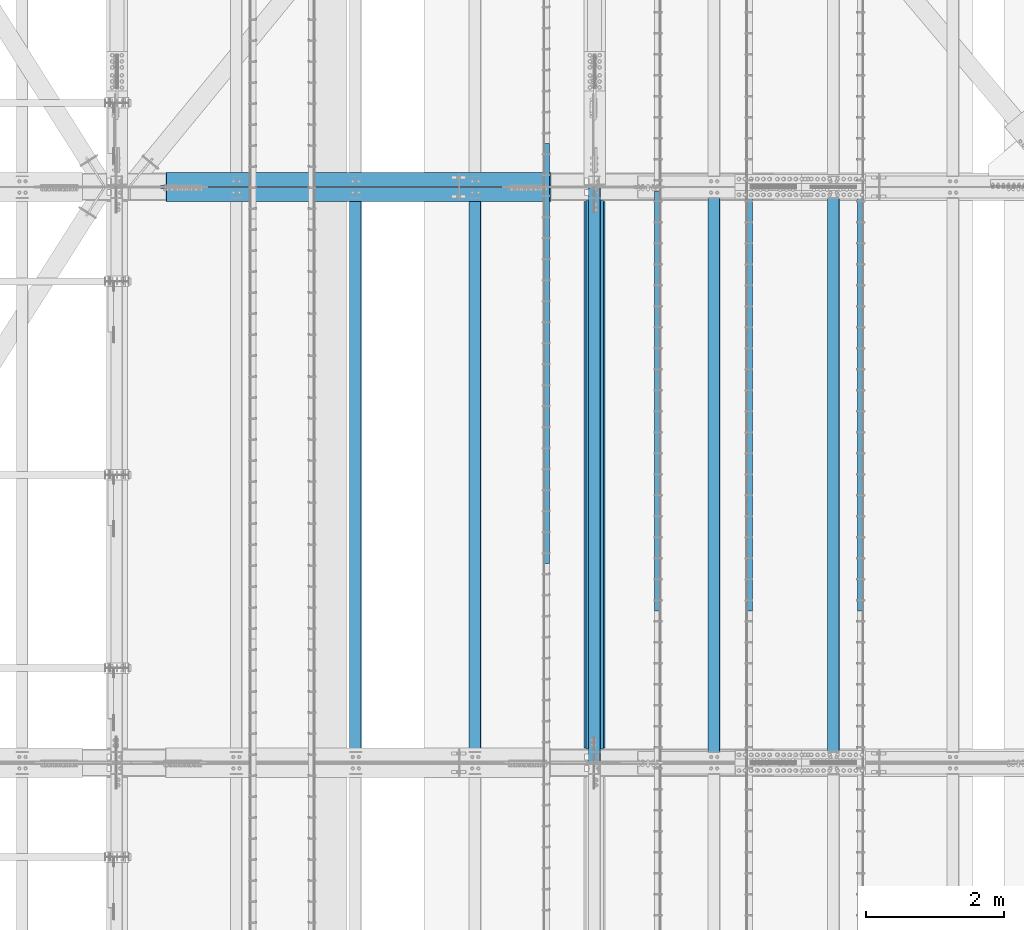
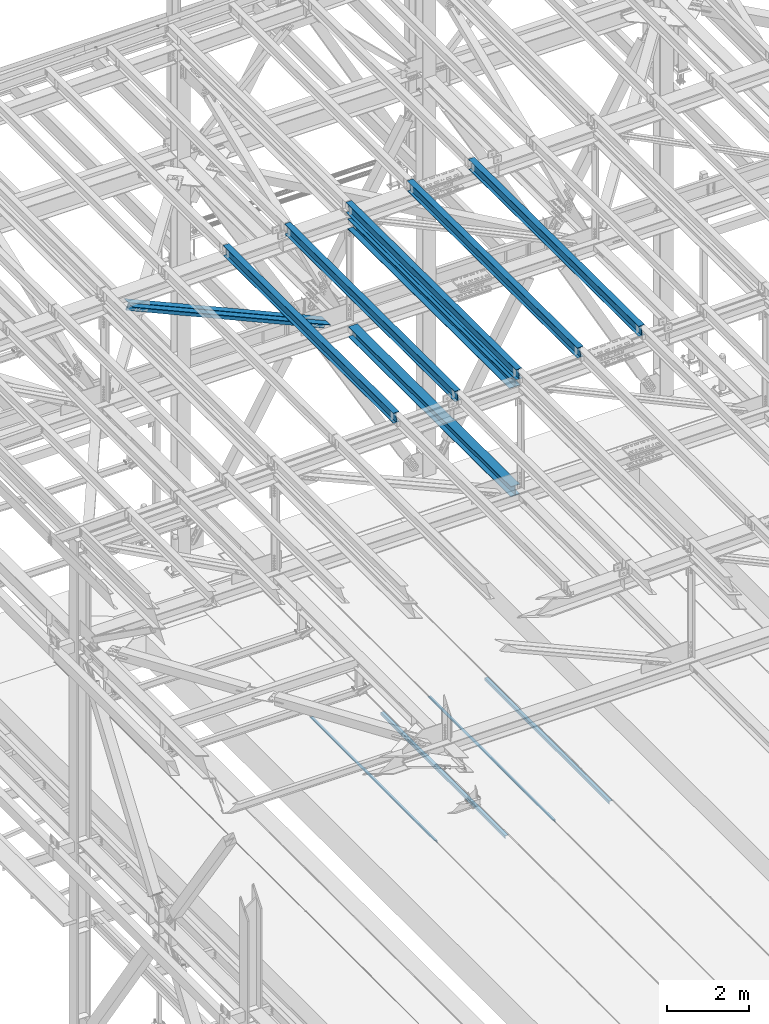
# One storey, part 1908 of 3843: 11 beams, 2 members, 13 elements without a shape of their own.
"""IFC2X3 building model written with IfcOpenShell, lengths in millimetres."""

from ifc_helpers import new_model, si_unit, frame, origin_with_axes, place, context, subcontext, project, spatial, faceted_brep, material, type_object, element, aggregate, save


model = new_model("IFC2X3")

# Units and contexts
model_context = context("Model", 3, precision=1e-05, world=origin_with_axes())
body_context = subcontext(model_context, "Body", "Model", "MODEL_VIEW")
ifc_project = project(units=[si_unit("LENGTHUNIT", "METRE", prefix="MILLI"), si_unit("AREAUNIT", "SQUARE_METRE"), si_unit("VOLUMEUNIT", "CUBIC_METRE"), si_unit("MASSUNIT", "GRAM", prefix="KILO"), si_unit("TIMEUNIT", "SECOND"), si_unit("PLANEANGLEUNIT", "RADIAN"), si_unit("SOLIDANGLEUNIT", "STERADIAN"), si_unit("THERMODYNAMICTEMPERATUREUNIT", "DEGREE_CELSIUS"), si_unit("LUMINOUSINTENSITYUNIT", "LUMEN")], contexts=[model_context])

# Site, building, storey
site_placement = place(None, origin_with_axes())
site = spatial("IfcSite", under=ifc_project, at=site_placement, CompositionType="ELEMENT")
building_placement = place(site_placement, origin_with_axes())
building = spatial("IfcBuilding", under=site, at=building_placement, Name="Undefined", CompositionType="ELEMENT")
storey_placement = place(building_placement, origin_with_axes())
storey = spatial("IfcBuildingStorey", under=building, at=storey_placement, Name="Undefined", CompositionType="ELEMENT", Elevation=0.0)

# Assembly, beam
assembly_1_placement = place(storey_placement, origin_with_axes())
assembly_1 = element("IfcElementAssembly", 1, at=assembly_1_placement, inside=storey, Name="EMBED_ANGLE", AssemblyPlace="NOTDEFINED", PredefinedType="RIGID_FRAME")
ifc_material_1 = material(Name="STEEL/A36")
beam_type_1 = type_object("IfcBeamType", Name="L3-1/2X3-1/2X5/16", PredefinedType="NOTDEFINED")
beam_1_placement = place(assembly_1_placement, frame((52851.812, 83927.822703125, 30410.15), z_axis=(0.0, 0.0, -1.0), x_axis=(0.0, -1.0, 0.0)))
beam_1 = element("IfcBeam", 2, at=beam_1_placement, type_object=beam_type_1, material=ifc_material_1, Name="EMBED_ANGLE", ObjectType="L3-1/2X3-1/2X5/16", context=body_context, shape_type="Brep", body=[
    faceted_brep([(-3.63797880709171e-12, 44.4499999999971, -44.4500000000007), (-3.63797880709171e-12, 44.4499999999971, 44.4500000000007), (6096.0, 44.4499999999971, 44.4500000000007), (6096.0, 44.4499999999971, -44.4500000000007), (-3.63797880709171e-12, 36.5124999999971, 44.4500000000007), (6096.0, 36.5124999999971, 44.4500000000007), (-3.63797880709171e-12, 36.5124999999971, -36.5125000000007), (6096.0, 36.5124999999971, -36.5125000000007), (3.63797880709171e-12, -44.4499999999971, -36.5125000000007), (6096.0, -44.4499999999971, -36.5125000000007), (3.63797880709171e-12, -44.4499999999971, -44.4500000000007), (6096.0, -44.4499999999971, -44.4500000000007)], [[[0, 1, 2, 3]], [[1, 4, 5, 2]], [[4, 6, 7, 5]], [[6, 8, 9, 7]], [[8, 10, 11, 9]], [[10, 0, 3, 11]], [[5, 7, 9, 11, 3, 2]], [[10, 8, 6, 4, 1, 0]]]),
])
aggregate(assembly_1, [beam_1])

assembly_2_placement = place(storey_placement, origin_with_axes())
assembly_2 = element("IfcElementAssembly", 3, at=assembly_2_placement, inside=storey, Name="EMBED_ANGLE", AssemblyPlace="NOTDEFINED", PredefinedType="RIGID_FRAME")
beam_2_placement = place(assembly_2_placement, frame((51238.9754423828, 77831.822703125, 30410.15), z_axis=(0.0, 0.0, -1.0), x_axis=(0.0, 1.0, 0.0)))
beam_2 = element("IfcBeam", 4, at=beam_2_placement, type_object=beam_type_1, material=ifc_material_1, Name="EMBED_ANGLE", ObjectType="L3-1/2X3-1/2X5/16", context=body_context, shape_type="Brep", body=[
    faceted_brep([(-3.63797880709171e-12, 44.4499999999971, -44.4500000000007), (-3.63797880709171e-12, 44.4499999999971, 44.4500000000007), (6096.0, 44.4499999999971, 44.4500000000007), (6096.0, 44.4499999999971, -44.4500000000007), (-3.63797880709171e-12, 36.5124999999971, 44.4500000000007), (6096.0, 36.5124999999971, 44.4500000000007), (-3.63797880709171e-12, 36.5124999999971, -36.5125000000007), (6096.0, 36.5124999999971, -36.5125000000007), (3.63797880709171e-12, -44.4499999999971, -36.5125000000007), (6096.0, -44.4499999999971, -36.5125000000007), (3.63797880709171e-12, -44.4499999999971, -44.4500000000007), (6096.0, -44.4499999999971, -44.4500000000007)], [[[0, 1, 2, 3]], [[1, 4, 5, 2]], [[4, 6, 7, 5]], [[6, 8, 9, 7]], [[8, 10, 11, 9]], [[10, 0, 3, 11]], [[5, 7, 9, 11, 3, 2]], [[10, 8, 6, 4, 1, 0]]]),
])
aggregate(assembly_2, [beam_2])

assembly_3_placement = place(storey_placement, origin_with_axes())
assembly_3 = element("IfcElementAssembly", 5, at=assembly_3_placement, inside=storey, Name="EMBED_ANGLE", AssemblyPlace="NOTDEFINED", PredefinedType="RIGID_FRAME")
beam_3_placement = place(assembly_3_placement, frame((49911.7620576172, 83927.822703125, 30410.15), z_axis=(0.0, 0.0, -1.0), x_axis=(0.0, -1.0, 0.0)))
beam_3 = element("IfcBeam", 6, at=beam_3_placement, type_object=beam_type_1, material=ifc_material_1, Name="EMBED_ANGLE", ObjectType="L3-1/2X3-1/2X5/16", context=body_context, shape_type="Brep", body=[
    faceted_brep([(-3.63797880709171e-12, 44.4499999999971, -44.4500000000007), (-3.63797880709171e-12, 44.4499999999971, 44.4500000000007), (6096.0, 44.4499999999971, 44.4500000000007), (6096.0, 44.4499999999971, -44.4500000000007), (-3.63797880709171e-12, 36.5124999999971, 44.4500000000007), (6096.0, 36.5124999999971, 44.4500000000007), (-3.63797880709171e-12, 36.5124999999971, -36.5125000000007), (6096.0, 36.5124999999971, -36.5125000000007), (3.63797880709171e-12, -44.4499999999971, -36.5125000000007), (6096.0, -44.4499999999971, -36.5125000000007), (3.63797880709171e-12, -44.4499999999971, -44.4500000000007), (6096.0, -44.4499999999971, -44.4500000000007)], [[[0, 1, 2, 3]], [[1, 4, 5, 2]], [[4, 6, 7, 5]], [[6, 8, 9, 7]], [[8, 10, 11, 9]], [[10, 0, 3, 11]], [[5, 7, 9, 11, 3, 2]], [[10, 8, 6, 4, 1, 0]]]),
])
aggregate(assembly_3, [beam_3])

assembly_4_placement = place(storey_placement, origin_with_axes())
assembly_4 = element("IfcElementAssembly", 7, at=assembly_4_placement, inside=storey, Name="EMBED_ANGLE", AssemblyPlace="NOTDEFINED", PredefinedType="RIGID_FRAME")
beam_4_placement = place(assembly_4_placement, frame((48298.8616210938, 78517.6230224609, 30410.15), z_axis=(0.0, 0.0, -1.0), x_axis=(0.0, 1.0, 0.0)))
beam_4 = element("IfcBeam", 8, at=beam_4_placement, type_object=beam_type_1, material=ifc_material_1, Name="EMBED_ANGLE", ObjectType="L3-1/2X3-1/2X5/16", context=body_context, shape_type="Brep", body=[
    faceted_brep([(-3.63797880709171e-12, 44.4499999999971, -44.4500000000007), (-3.63797880709171e-12, 44.4499999999971, 44.4500000000007), (6096.0, 44.4499999999971, 44.4500000000007), (6096.0, 44.4499999999971, -44.4500000000007), (-3.63797880709171e-12, 36.5124999999971, 44.4500000000007), (6096.0, 36.5124999999971, 44.4500000000007), (-3.63797880709171e-12, 36.5124999999971, -36.5125000000007), (6096.0, 36.5124999999971, -36.5125000000007), (3.63797880709171e-12, -44.4499999999971, -36.5125000000007), (6096.0, -44.4499999999971, -36.5125000000007), (3.63797880709171e-12, -44.4499999999971, -44.4500000000007), (6096.0, -44.4499999999971, -44.4500000000007)], [[[0, 1, 2, 3]], [[1, 4, 5, 2]], [[4, 6, 7, 5]], [[6, 8, 9, 7]], [[8, 10, 11, 9]], [[10, 0, 3, 11]], [[5, 7, 9, 11, 3, 2]], [[10, 8, 6, 4, 1, 0]]]),
])
aggregate(assembly_4, [beam_4])

assembly_5_placement = place(storey_placement, origin_with_axes())
assembly_5 = element("IfcElementAssembly", 9, at=assembly_5_placement, inside=storey, Name="BEAM", AssemblyPlace="NOTDEFINED", PredefinedType="RIGID_FRAME")
ifc_material_2 = material(Name="STEEL/A992")
beam_type_2 = type_object("IfcBeamType", Name="W12X26", PredefinedType="NOTDEFINED")
beam_5_placement = place(assembly_5_placement, frame((48993.309262336, 75629.3544032389, 45888.5907153164), z_axis=(-0.0211520981352297, 0.00549190600185831, 0.999761185340251), x_axis=(0.0, 0.999984912620133, -0.0054931349979134)))
beam_5 = element("IfcBeam", 10, at=beam_5_placement, type_object=beam_type_2, material=ifc_material_2, Name="BEAM", ObjectType="W12X26", context=body_context, shape_type="Brep", body=[
    faceted_brep([(12.7097787592938, 82.5500000013999, -155.574999999641), (12.6575034070993, 82.5500000013417, -146.049999999654), (8343.98317003538, 82.549999999188, -146.04999997573), (8344.03548122934, 82.5499999991807, -155.574999975695), (12.6482846770959, 3.17500000093423, -146.049999999646), (8343.97394720899, 3.17499999931169, -146.049999975723), (11.0440394217876, 3.17500000016298, 146.049999999559), (8342.36973726093, 3.17499999965366, 146.050000023322), (11.0532622481842, 82.5500000000247, 146.049999999566), (8342.37896008733, 82.5499999995154, 146.050000023322), (11.0009510542295, 82.5500000000393, 155.574999999531), (8342.32664889337, 82.54999999953, 155.57500002328), (10.9817675753293, -82.5499999996973, 155.574999999539), (8342.30746541447, -82.5500000001994, 155.575000023295), (11.0340787692694, -82.5499999996973, 146.049999999566), (8342.35977660841, -82.5500000002066, 146.050000023322), (11.0433015956805, -3.17499999982829, 146.049999999566), (8342.36899943482, -3.1750000003376, 146.050000023315), (12.6475471787126, -3.17499999911524, -146.049999999639), (8343.97320938286, -3.17500000067957, -146.04999997573), (12.6383284487092, -82.5499999995518, -146.049999999625), (8343.96398655647, -82.5500000005413, -146.049999975723), (12.6906038008892, -82.5499999994936, -155.574999999611), (8344.01629775044, -82.5500000005559, -155.574999975695)], [[[0, 1, 2, 3]], [[1, 4, 5, 2]], [[4, 6, 7, 5]], [[6, 8, 9, 7]], [[8, 10, 11, 9]], [[10, 12, 13, 11]], [[12, 14, 15, 13]], [[14, 16, 17, 15]], [[16, 18, 19, 17]], [[18, 20, 21, 19]], [[20, 22, 23, 21]], [[22, 0, 3, 23]], [[5, 7, 9, 11, 13, 15, 17, 19, 21, 23, 3, 2]], [[22, 20, 18, 16, 14, 12, 10, 8, 6, 4, 1, 0]]]),
])
aggregate(assembly_5, [beam_5])

assembly_6_placement = place(storey_placement, origin_with_axes())
assembly_6 = element("IfcElementAssembly", 11, at=assembly_6_placement, inside=storey, Name="BEAM", AssemblyPlace="NOTDEFINED", PredefinedType="RIGID_FRAME")
beam_6_placement = place(assembly_6_placement, frame((52460.4092623552, 75629.5061975702, 45971.7712506336), z_axis=(-0.0211520976052125, 0.00646760500322854, 0.999755349499277), x_axis=(0.0, 0.999979075464173, -0.00646905200300302)))
beam_6 = element("IfcBeam", 12, at=beam_6_placement, type_object=beam_type_2, material=ifc_material_2, Name="BEAM", ObjectType="W12X26", context=body_context, shape_type="Brep", body=[
    faceted_brep([(12.711561660195, 82.5500000001848, -155.574999999531), (12.6499564365658, 82.5500000001557, -146.049999999559), (8344.02428661397, 82.5499999998356, -146.049999984367), (8344.08589183762, 82.5499999998647, -155.574999984347), (12.6390950083442, 3.17500000028667, -146.049999999625), (8344.01342518577, 3.17499999996653, -146.049999984432), (10.7498681504803, 3.17499999969732, 146.049999999661), (8342.1241983279, 3.17499999937718, 146.050000014853), (10.7607295786875, 82.5499999995736, 146.049999999734), (8342.13505975612, 82.5499999992535, 146.050000014919), (10.6991243550729, 82.5499999995518, 155.574999999706), (8342.0734545325, 82.5499999992317, 155.575000014891), (10.676532584388, -82.5500000001921, 155.574999999582), (8342.05086276181, -82.5500000005122, 155.575000014775), (10.7381378080026, -82.550000000163, 146.049999999603), (8342.11246798544, -82.5500000004831, 146.050000014795), (10.7489992362243, -3.17500000029395, 146.049999999661), (8342.12332941365, -3.17500000061409, 146.050000014853), (12.6382260940882, -3.1749999997046, -146.049999999625), (8344.01255627151, -3.17500000002474, -146.049999984432), (12.627364665881, -82.5499999995809, -146.049999999675), (8344.00169484329, -82.549999999901, -146.049999984491), (12.6889698895102, -82.5499999995591, -155.57499999967), (8344.06330006692, -82.5499999998792, -155.57499998447)], [[[0, 1, 2, 3]], [[1, 4, 5, 2]], [[4, 6, 7, 5]], [[6, 8, 9, 7]], [[8, 10, 11, 9]], [[10, 12, 13, 11]], [[12, 14, 15, 13]], [[14, 16, 17, 15]], [[16, 18, 19, 17]], [[18, 20, 21, 19]], [[20, 22, 23, 21]], [[22, 0, 3, 23]], [[5, 7, 9, 11, 13, 15, 17, 19, 21, 23, 3, 2]], [[22, 20, 18, 16, 14, 12, 10, 8, 6, 4, 1, 0]]]),
])
aggregate(assembly_6, [beam_6])

assembly_7_placement = place(storey_placement, origin_with_axes())
assembly_7 = element("IfcElementAssembly", 13, at=assembly_7_placement, inside=storey, Name="BEAM", AssemblyPlace="NOTDEFINED", PredefinedType="RIGID_FRAME")
beam_7_placement = place(assembly_7_placement, frame((50726.8594949356, 75629.4357298818, 45930.4726800181), z_axis=(-0.0211520979501875, 0.00601465500060296, 0.999758177099607), x_axis=(-2.79999999977758e-08, 0.999981903702256, -0.00601600099820853)))
beam_7 = element("IfcBeam", 14, at=beam_7_placement, type_object=beam_type_2, material=ifc_material_2, Name="BEAM", ObjectType="W12X26", context=body_context, shape_type="Brep", body=[
    faceted_brep([(12.7107368839934, 82.5499999999956, -155.575000000114), (12.6534462637064, 82.5499999999884, -146.050000000105), (8344.0042128947, 82.5499999820022, -146.049999983406), (8344.06150351498, 82.5499999820095, -155.574999983422), (12.6433433078637, 3.1750000001266, -146.050000000017), (8343.99410993885, 3.17499998214043, -146.049999983319), (10.8864309522323, 3.17499999982101, 146.050000000068), (8342.23719758324, 3.17499998183484, 146.050000016767), (10.8965339080605, 82.5499999996755, 146.049999999974), (8342.24730053906, 82.5499999817039, 146.050000016679), (10.8392432877736, 82.5499999996755, 155.574999999983), (8342.19000991878, 82.5499999816893, 155.575000016674), (10.818229139637, -82.5500000000466, 155.575000000172), (8342.16899577064, -82.5500000180255, 155.57500001687), (10.8755197599239, -82.550000000032, 146.05000000017), (8342.22628639093, -82.5500000180109, 146.050000016869), (10.8856227157667, -3.17500000016298, 146.050000000076), (8342.23638934677, -3.17500001815642, 146.050000016774), (12.6425350713835, -3.17499999986467, -146.05000000001), (8343.9933017024, -3.17500001785083, -146.049999983319), (12.6324321155407, -82.5499999997337, -146.049999999916), (8343.98319874656, -82.5500000177126, -146.049999983217), (12.6897227358422, -82.5499999997191, -155.574999999917), (8344.04048936686, -82.5500000177053, -155.574999983219)], [[[0, 1, 2, 3]], [[1, 4, 5, 2]], [[4, 6, 7, 5]], [[6, 8, 9, 7]], [[8, 10, 11, 9]], [[10, 12, 13, 11]], [[12, 14, 15, 13]], [[14, 16, 17, 15]], [[16, 18, 19, 17]], [[18, 20, 21, 19]], [[20, 22, 23, 21]], [[22, 0, 3, 23]], [[5, 7, 9, 11, 13, 15, 17, 19, 21, 23, 3, 2]], [[22, 20, 18, 16, 14, 12, 10, 8, 6, 4, 1, 0]]]),
])
aggregate(assembly_7, [beam_7])

assembly_8_placement = place(storey_placement, origin_with_axes())
assembly_8 = element("IfcElementAssembly", 15, at=assembly_8_placement, inside=storey, Name="BEAM", AssemblyPlace="NOTDEFINED", PredefinedType="RIGID_FRAME")
beam_8_placement = place(assembly_8_placement, frame((47259.7592623296, 75629.2646229093, 45846.2545897156), z_axis=(-0.021152097592596, 0.00491481899929932, 0.999764188857371), x_axis=(0.0, 0.999987916802112, -0.00491591799902755)))
beam_8 = element("IfcBeam", 16, at=beam_8_placement, type_object=beam_type_2, material=ifc_material_2, Name="BEAM", ObjectType="W12X26", context=body_context, shape_type="Brep", body=[
    faceted_brep([(12.7087372003007, 82.5500000003158, -155.57500000023), (12.6619229916832, 82.5500000002867, -146.050000000214), (8343.962591755, 82.550000000112, -146.049999991679), (8344.00940596362, 82.5500000001339, -155.574999991695), (12.6536693221133, 3.17500000043219, -146.050000000265), (8343.95433808543, 3.17500000025757, -146.049999991723), (11.2180335913872, 3.17499999952997, 146.050000000279), (8342.51870235472, 3.17499999935535, 146.050000008821), (11.2262872609572, 82.5499999993845, 146.050000000323), (8342.52695602429, 82.5499999992026, 146.050000008865), (11.1794730523543, 82.5499999993626, 155.575000000346), (8342.48014181567, 82.549999999188, 155.575000008881), (11.1623054196389, -82.5500000003376, 155.575000000252), (8342.46297418297, -82.5500000005122, 155.575000008786), (11.2091196282563, -82.5500000003012, 146.050000000236), (8342.50978839157, -82.5500000004758, 146.05000000877), (11.2173732978263, -3.17500000045402, 146.050000000287), (8342.51804206114, -3.17500000062864, 146.050000008821), (12.6530090285523, -3.1749999995518, -146.050000000265), (8343.95367779187, -3.17499999972642, -146.04999999173), (12.6447553589969, -82.5499999994063, -146.050000000309), (8343.9454241223, -82.5499999995809, -146.049999991774), (12.6915695675852, -82.5499999993772, -155.575000000325), (8343.99223833092, -82.5499999995518, -155.57499999179)], [[[0, 1, 2, 3]], [[1, 4, 5, 2]], [[4, 6, 7, 5]], [[6, 8, 9, 7]], [[8, 10, 11, 9]], [[10, 12, 13, 11]], [[12, 14, 15, 13]], [[14, 16, 17, 15]], [[16, 18, 19, 17]], [[18, 20, 21, 19]], [[20, 22, 23, 21]], [[22, 0, 3, 23]], [[5, 7, 9, 11, 13, 15, 17, 19, 21, 23, 3, 2]], [[22, 20, 18, 16, 14, 12, 10, 8, 6, 4, 1, 0]]]),
])
aggregate(assembly_8, [beam_8])

assembly_9_placement = place(storey_placement, origin_with_axes())
assembly_9 = element("IfcElementAssembly", 17, at=assembly_9_placement, inside=storey, Name="BEAM", AssemblyPlace="NOTDEFINED", PredefinedType="RIGID_FRAME")
beam_9_placement = place(assembly_9_placement, frame((45526.2092623427, 75629.1652799087, 45803.4047149413), z_axis=(-0.0211520984919553, 0.00427626500010956, 0.999767124027909), x_axis=(0.0, 0.999990852644151, -0.00427722199847777)))
beam_9 = element("IfcBeam", 18, at=beam_9_placement, type_object=beam_type_2, material=ifc_material_2, Name="BEAM", ObjectType="W12X26", context=body_context, shape_type="Brep", body=[
    faceted_brep([(12.7075847479573, 82.549999999821, -155.575000000259), (12.6668529507879, 82.5499999998283, -146.050000000221), (8343.94306197949, 82.5499999995227, -146.049999986048), (8343.98379377666, 82.5499999995154, -155.574999986085), (12.6596716532367, 3.17499999996653, -146.050000000498), (8343.93588068195, 3.17499999966822, -146.049999986324), (11.4105632065912, 3.17500000002474, 146.050000000556), (8342.68677223532, 3.17499999971915, 146.050000014729), (11.4177445041132, 82.5499999998647, 146.050000000832), (8342.69395353284, 82.5499999995591, 146.050000015013), (11.3770127069438, 82.5499999998719, 155.575000000863), (8342.65322173566, 82.5499999995664, 155.575000015051), (11.3620756080782, -82.549999999821, 155.575000000295), (8342.63828463681, -82.5500000001266, 155.575000014469), (11.4028074052476, -82.549999999821, 146.050000000258), (8342.67901643398, -82.5500000001266, 146.050000014431), (11.4099887027842, -3.17499999997381, 146.050000000534), (8342.68619773151, -3.17500000027212, 146.050000014708), (12.6590971494443, -3.17500000001746, -146.05000000052), (8343.93530617816, -3.17500000032305, -146.049999986346), (12.6519158519222, -82.5499999998647, -146.050000000803), (8343.92812488062, -82.5500000001703, -146.049999986615), (12.6926476490917, -82.5499999998719, -155.575000000834), (8343.96885667781, -82.5500000001703, -155.574999986653)], [[[0, 1, 2, 3]], [[1, 4, 5, 2]], [[4, 6, 7, 5]], [[6, 8, 9, 7]], [[8, 10, 11, 9]], [[10, 12, 13, 11]], [[12, 14, 15, 13]], [[14, 16, 17, 15]], [[16, 18, 19, 17]], [[18, 20, 21, 19]], [[20, 22, 23, 21]], [[22, 0, 3, 23]], [[5, 7, 9, 11, 13, 15, 17, 19, 21, 23, 3, 2]], [[22, 20, 18, 16, 14, 12, 10, 8, 6, 4, 1, 0]]]),
])
aggregate(assembly_9, [beam_9])

# Assembly, member
assembly_10_placement = place(storey_placement, origin_with_axes())
assembly_10 = element("IfcElementAssembly", 19, at=assembly_10_placement, inside=storey, Name="ANGLE", AssemblyPlace="NOTDEFINED", PredefinedType="RIGID_FRAME")
ifc_material_3 = material(Name="STEEL/A572-50")
member_type = type_object("IfcMemberType", Name="L8X8X1/2", PredefinedType="NOTDEFINED")
member_1_placement = place(assembly_10_placement, frame((42062.4, 84096.225, 45340.2008418066), z_axis=(-0.40677504213863, 0.0, -0.913528360311335), x_axis=(0.913528360311335, 0.0, -0.406775042138631)))
member_1 = element("IfcMember", 20, at=member_1_placement, type_object=member_type, material=ifc_material_3, Name="ANGLE", ObjectType="L8X8X1/2", context=body_context, shape_type="Brep", body=[
    faceted_brep([(737.682505146517, 101.599999999999, -101.599999999773), (737.682505146095, 101.599999999999, 101.599999999955), (6848.10201020961, 101.599999999999, 101.600000000726), (6848.10201021003, 101.599999999999, -101.599999999002), (737.682505146095, 88.9000000000015, 101.599999999955), (6848.10201020961, 88.9000000000015, 101.600000000726), (737.682505146491, 88.9000000000015, -88.8999999997977), (6848.10201021001, 88.9000000000015, -88.8999999990119), (737.682505146491, -101.599999999999, -88.8999999997977), (6848.10201021001, -101.599999999999, -88.8999999990119), (737.682505146517, -101.599999999999, -101.599999999773), (6848.10201021003, -101.599999999999, -101.599999999002)], [[[0, 1, 2, 3]], [[1, 4, 5, 2]], [[4, 6, 7, 5]], [[6, 8, 9, 7]], [[8, 10, 11, 9]], [[10, 0, 3, 11]], [[5, 7, 9, 11, 3, 2]], [[10, 8, 6, 4, 1, 0]]]),
])
aggregate(assembly_10, [member_1])

assembly_11_placement = place(storey_placement, origin_with_axes())
assembly_11 = element("IfcElementAssembly", 21, at=assembly_11_placement, inside=storey, Name="ANGLE", AssemblyPlace="NOTDEFINED", PredefinedType="RIGID_FRAME")
member_2_placement = place(assembly_11_placement, frame((48996.6000001136, 83873.975, 42252.5468530739), z_axis=(-0.40677504213863, 0.0, -0.913528360311335), x_axis=(-0.913528360311335, 0.0, 0.406775042138629)))
member_2 = element("IfcMember", 22, at=member_2_placement, type_object=member_type, material=ifc_material_3, Name="ANGLE", ObjectType="L8X8X1/2", context=body_context, shape_type="Brep", body=[
    faceted_brep([(742.466927323894, 101.599999999999, -101.599999999955), (742.46692732432, 101.599999999999, 101.599999999758), (6852.88643238783, 101.599999999999, 101.599999998987), (6852.8864323874, 101.599999999999, -101.600000000733), (742.46692732432, 88.9000000000015, 101.599999999758), (6852.88643238783, 88.9000000000015, 101.599999998987), (742.46692732392, 88.9000000000015, -88.8999999999796), (6852.88643238743, 88.9000000000015, -88.9000000007436), (742.46692732392, -101.599999999999, -88.8999999999796), (6852.88643238743, -101.599999999999, -88.9000000007436), (742.466927323894, -101.599999999999, -101.599999999955), (6852.8864323874, -101.599999999999, -101.600000000733)], [[[0, 1, 2, 3]], [[1, 4, 5, 2]], [[4, 6, 7, 5]], [[6, 8, 9, 7]], [[8, 10, 11, 9]], [[10, 0, 3, 11]], [[5, 7, 9, 11, 3, 2]], [[10, 8, 6, 4, 1, 0]]]),
])
aggregate(assembly_11, [member_2])

# Assembly, beam
assembly_12_placement = place(storey_placement, origin_with_axes())
assembly_12 = element("IfcElementAssembly", 23, at=assembly_12_placement, inside=storey, Name="BEAM", AssemblyPlace="NOTDEFINED", PredefinedType="RIGID_FRAME")
beam_type_3 = type_object("IfcBeamType", Name="W12X65", PredefinedType="NOTDEFINED")
beam_10_placement = place(assembly_12_placement, frame((48996.6, 75628.4999999989, 45536.1452598678), z_axis=(0.0, 0.00549175500110143, 0.999984920199804), x_axis=(0.0, 0.999984920199804, -0.00549175500109727)))
beam_10 = element("IfcBeam", 24, at=beam_10_placement, type_object=beam_type_3, material=ifc_material_2, Name="BEAM", ObjectType="W12X65", context=body_context, shape_type="Brep", body=[
    faceted_brep([(213.573882275727, 152.400000000001, -153.987499999836), (213.486699350382, 152.400000000001, -138.112499999843), (8144.75630130629, 152.400000000001, -138.112499995499), (8144.84348423163, 152.400000000001, -153.987499995492), (213.486699350382, 4.76249999999709, -138.112499999843), (8144.75630130629, 4.76249999999709, -138.112499995499), (211.969716449399, 4.76249999999709, 138.112500000076), (8143.23931840529, 4.76249999999709, 138.112500004412), (211.969716449399, 152.400000000001, 138.112500000076), (8143.23931840529, 152.400000000001, 138.112500004412), (211.882533524054, 152.400000000001, 153.987500000068), (8143.15213547995, 152.400000000001, 153.987500004412), (211.882533524054, -152.400000000001, 153.987500000068), (8143.15213547995, -152.400000000001, 153.987500004412), (211.969716449399, -152.400000000001, 138.112500000076), (8143.23931840529, -152.400000000001, 138.112500004412), (211.969716449399, -4.76249999999709, 138.112500000076), (8143.23931840529, -4.76249999999709, 138.112500004412), (213.486699350382, -4.76249999999709, -138.112499999843), (8144.75630130629, -4.76249999999709, -138.112499995499), (213.486699350382, -152.400000000001, -138.112499999843), (8144.75630130629, -152.400000000001, -138.112499995499), (213.573882275727, -152.400000000001, -153.987499999836), (8144.84348423163, -152.400000000001, -153.987499995492)], [[[0, 1, 2, 3]], [[1, 4, 5, 2]], [[4, 6, 7, 5]], [[6, 8, 9, 7]], [[8, 10, 11, 9]], [[10, 12, 13, 11]], [[12, 14, 15, 13]], [[14, 16, 17, 15]], [[16, 18, 19, 17]], [[18, 20, 21, 19]], [[20, 22, 23, 21]], [[22, 0, 3, 23]], [[5, 7, 9, 11, 13, 15, 17, 19, 21, 23, 3, 2]], [[22, 20, 18, 16, 14, 12, 10, 8, 6, 4, 1, 0]]]),
])
aggregate(assembly_12, [beam_10])

assembly_13_placement = place(storey_placement, origin_with_axes())
assembly_13 = element("IfcElementAssembly", 25, at=assembly_13_placement, inside=storey, Name="BEAM", AssemblyPlace="NOTDEFINED", PredefinedType="RIGID_FRAME")
beam_type_4 = type_object("IfcBeamType", Name="W12X53", PredefinedType="NOTDEFINED")
beam_11_placement = place(assembly_13_placement, frame((48996.6, 75628.4999999989, 42298.454665512), z_axis=(0.0, 0.00549351699737598, 0.999984910521654), x_axis=(0.0, 0.999984912620133, -0.0054931349979134)))
beam_11 = element("IfcBeam", 26, at=beam_11_placement, type_object=beam_type_4, material=ifc_material_2, Name="BEAM", ObjectType="W12X53", context=body_context, shape_type="Brep", body=[
    faceted_brep([(199.277718989746, 127.0, -152.400000000118), (199.199229181162, 127.0, -138.112500000097), (8159.04433910428, 127.0, -138.112500000097), (8159.12282891286, 127.0, -152.400000000111), (199.199229181162, 4.76249999999709, -138.112500000097), (8159.04433910428, 4.76249999999709, -138.112500000097), (197.681759548737, 4.76249999999709, 138.112500000112), (8157.52686947185, 4.76249999999709, 138.112500000119), (197.681759548737, 127.0, 138.112500000112), (8157.52686947185, 127.0, 138.112500000119), (197.603269740168, 127.0, 152.400000000118), (8157.44837966327, 127.0, 152.400000000132), (197.603269740168, -127.0, 152.400000000118), (8157.44837966327, -127.0, 152.400000000132), (197.681759548737, -127.0, 138.112500000112), (8157.52686947185, -127.0, 138.112500000119), (197.681759548737, -4.76249999999709, 138.112500000112), (8157.52686947185, -4.76249999999709, 138.112500000119), (199.199229181162, -4.76249999999709, -138.112500000097), (8159.04433910428, -4.76249999999709, -138.112500000097), (199.199229181162, -127.0, -138.112500000097), (8159.04433910428, -127.0, -138.112500000097), (199.277718989746, -127.0, -152.400000000118), (8159.12282891286, -127.0, -152.400000000111)], [[[0, 1, 2, 3]], [[1, 4, 5, 2]], [[4, 6, 7, 5]], [[6, 8, 9, 7]], [[8, 10, 11, 9]], [[10, 12, 13, 11]], [[12, 14, 15, 13]], [[14, 16, 17, 15]], [[16, 18, 19, 17]], [[18, 20, 21, 19]], [[20, 22, 23, 21]], [[22, 0, 3, 23]], [[5, 7, 9, 11, 13, 15, 17, 19, 21, 23, 3, 2]], [[22, 20, 18, 16, 14, 12, 10, 8, 6, 4, 1, 0]]]),
])
aggregate(assembly_13, [beam_11])

save(model, "model.ifc")
